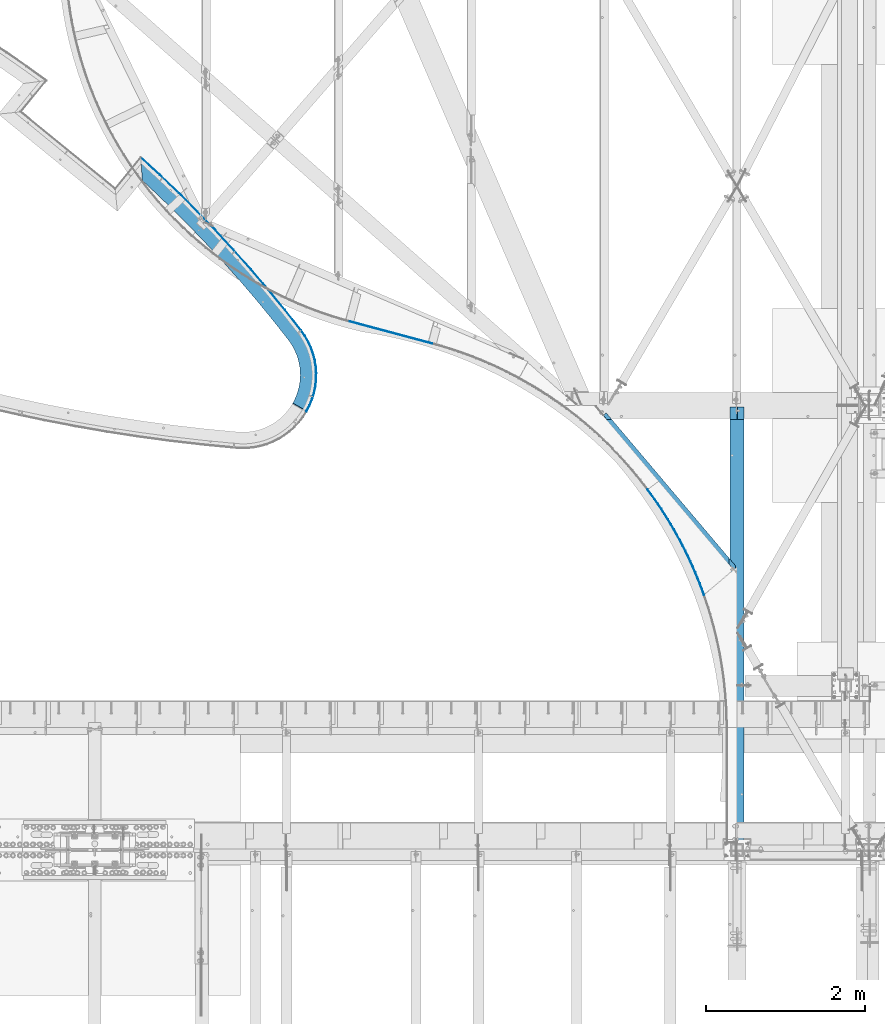
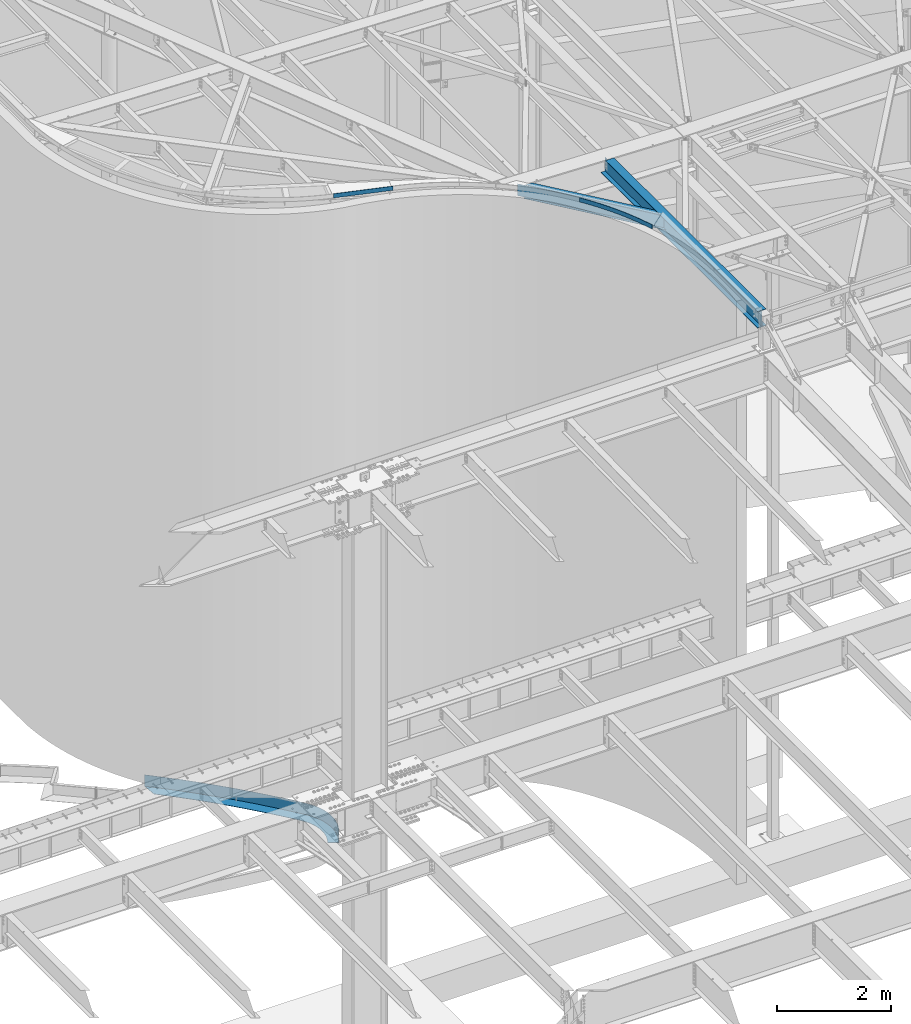
# One storey, part 1147 of 1763: 6 beams, 4 elements without a shape of their own.
"""IFC2X3 building model written with IfcOpenShell, lengths in millimetres."""

from ifc_helpers import new_model, si_unit, frame, origin_with_axes, place, context, subcontext, project, spatial, faceted_brep, material, type_object, element, aggregate, save


model = new_model("IFC2X3")

# Units and contexts
model_context = context("Model", 3, precision=1e-05, world=origin_with_axes())
body_context = subcontext(model_context, "Body", "Model", "MODEL_VIEW")
ifc_project = project(units=[si_unit("LENGTHUNIT", "METRE", prefix="MILLI"), si_unit("AREAUNIT", "SQUARE_METRE"), si_unit("VOLUMEUNIT", "CUBIC_METRE"), si_unit("MASSUNIT", "GRAM", prefix="KILO"), si_unit("TIMEUNIT", "SECOND"), si_unit("PLANEANGLEUNIT", "RADIAN"), si_unit("SOLIDANGLEUNIT", "STERADIAN"), si_unit("THERMODYNAMICTEMPERATUREUNIT", "DEGREE_CELSIUS"), si_unit("LUMINOUSINTENSITYUNIT", "LUMEN")], contexts=[model_context])

# Site, building, storey
site_placement = place(None, origin_with_axes())
site = spatial("IfcSite", under=ifc_project, at=site_placement, CompositionType="ELEMENT")
building_placement = place(site_placement, origin_with_axes())
building = spatial("IfcBuilding", under=site, at=building_placement, Name="Undefined", CompositionType="ELEMENT")
storey_placement = place(building_placement, origin_with_axes())
storey = spatial("IfcBuildingStorey", under=building, at=storey_placement, Name="Undefined", CompositionType="ELEMENT", Elevation=0.0)

# Assembly, beams
assembly_1_placement = place(storey_placement, origin_with_axes())
assembly_1 = element("IfcElementAssembly", 1, at=assembly_1_placement, inside=storey, Name="PLATE", AssemblyPlace="NOTDEFINED", PredefinedType="RIGID_FRAME")
ifc_material_1 = material(Name="STEEL/A36")
beam_type_1 = type_object("IfcBeamType", PredefinedType="NOTDEFINED")
beam_1_placement = place(assembly_1_placement, frame((-48899.7311067183, 60744.4936848839, -250.825), z_axis=(-0.700889581172582, -0.713269791175627, 0.0), x_axis=(0.713269791175628, -0.700889581172581, 0.0)))
beam_1 = element("IfcBeam", 2, at=beam_1_placement, type_object=beam_type_1, material=ifc_material_1, Name="PLATE", context=body_context, shape_type="Brep", body=[
    faceted_brep([(3719.33623650917, 7.91079060036282e-08, 714.45913053512), (3717.48053077907, 3.17499973110492, 708.380531383253), (3526.81825230109, 3.17500026889508, 758.027630323701), (3528.67394264099, 9.33366379740619e-08, 764.106170379902), (3494.29718461835, 3.17500026889508, 664.28157329591), (3494.29718460236, -3.17499973110492, 664.281573302684), (3513.43892058598, -3.17499973110492, 714.20199762013), (3513.43892060238, 3.17500026889508, 714.201997614484), (3471.71765696332, 3.17500026889508, 615.825898084116), (3471.71765694785, -3.17499973110492, 615.825898091989), (3445.79959073293, 3.17500026889508, 569.052919037789), (3445.79959071806, -3.17499973110492, 569.052919046724), (3417.40967095453, 3.17500026889508, 525.336417431874), (3417.40967094037, -3.17499973110492, 525.336417441937), (3385.86149135047, 3.17500026889508, 484.683425487088), (3385.86149124734, -3.17499973110492, 484.683425382475), (3348.17159766036, 3.17500272120952, 443.143611717485), (3348.17159756071, -3.17499727879047, 443.143611616699), (3347.48148950403, 3.17500271957653, 442.442355498355), (3347.48148950389, -3.17499728042347, 442.442355498493), (3311.82468044292, -3.17499728041125, 408.47127432629), (3311.82468044305, 3.17500271958875, 408.471274326144), (3274.05442623266, 3.17500271719913, 376.866681538017), (3274.05442623263, -3.17499728280086, 376.866681538046), (3273.27991684059, 3.17500271496723, 376.259928631091), (3273.27991684056, -3.17499728503279, 376.259928631134), (3227.7524592525, 3.17500000061955, 343.482356215845), (3227.75245925249, -3.17499999938045, 343.482356215882), (3183.80776864987, 3.17500000061955, 316.708360037901), (3183.80776864986, -3.17499999938045, 316.708360037945), (3137.18097810568, 3.17500000061955, 293.42634960567), (3137.18097810568, -3.17499999938045, 293.426349605706), (3087.78670530255, 3.17500000061955, 272.940252532742), (3087.78670530253, -3.17499999938045, 272.940252532779), (3037.09656629767, 3.17500000061955, 255.961054376832), (3037.09656629765, -3.17499999938045, 255.961054376861), (2985.33463682051, 3.17500000061955, 242.561818135055), (2985.33463682017, -3.17499999938045, 242.561818135004), (2930.38702798114, 3.17500000627177, 232.365032070429), (2930.3870279808, -3.17499999372822, 232.365032070385), (2929.39717863227, 3.17500000623701, 232.227819105432), (2929.39717863229, -3.17499999376298, 232.227819105432), (2606.76330909597, -3.17499999506504, 190.856892663844), (2606.76330909594, 3.17500000493496, 190.856892663844), (2283.35200185691, -3.17499999621518, 156.081992570125), (2283.35200185688, 3.17500000378482, 156.081992570118), (1959.29809386149, -3.17499999721298, 127.917617208335), (1959.29809386148, 3.17500000278702, 127.917617208335), (1634.73668996988, -3.17499999805798, 106.375508896348), (1634.73668996988, 3.17500000194201, 106.375508896348), (1309.80310662788, -3.17499999874988, 91.4646489902188), (1309.80310662788, 3.17500000125011, 91.4646489902188), (984.632815450692, -3.17499999928833, 83.1912541396923), (984.632815450677, 3.17500000071166, 83.1912541396923), (659.361386741963, -3.17499999967313, 81.5587736963171), (659.361386741963, 3.17500000032686, 81.5587736963171), (334.124432971716, -3.17499999990412, 86.5678882753818), (334.124432971716, 3.17500000009588, 86.5678882753891), (222.037116683074, 3.1750000000693, 90.5844853690542), (222.037116683074, -3.17499999993072, 90.5844853690542), (6.65585226372059, 3.17499999998279, -98.6635093847108), (6.65585226372059, -3.17500000001721, -98.6635093847108), (329.083712204767, 3.17500000005927, -110.217562492919), (329.083712204767, -3.17499999994075, -110.217562492919), (658.339599024868, 3.1750000002931, -115.288574392998), (658.339599024868, -3.1749999997069, -115.288574392998), (987.630386788151, 3.17500000068267, -113.635921489116), (987.63038678818, -3.17499999931732, -113.635921489116), (1316.81878726966, 3.17500000122777, -105.260292806863), (1316.81878726966, -3.17499999877222, -105.260292806863), (1645.76755493179, 3.1750000019282, -90.165180321248), (1645.76755493179, -3.1749999980718, -90.1651803212408), (1974.33954414494, 3.17500000278363, -68.3568775007552), (1974.33954414494, -3.17499999721636, -68.3568775007407), (2302.39776636627, 3.17500000379377, -39.8444766834909), (2302.39776636628, -3.17499999620622, -39.8444766834982), (2629.80544725322, 3.17500000495815, -4.63986528645546), (2629.80544725325, -3.17499999504187, -4.63986528645546), (2956.42608368752, 3.1750000062373, 37.2422791506651), (2956.4260836875, -3.17499999372373, 37.2422791506651), (2961.87635873359, 3.17500000622621, 37.9977965432881), (2961.87635873327, -3.17499999377378, 37.9977965432445), (3028.01057783778, 3.17499999938045, 50.2705141009828), (3028.01057783746, -3.17500000061955, 50.2705141009392), (3093.09187443195, 3.17499999938045, 67.1176385570216), (3093.09187443195, -3.17500000061955, 67.1176385570579), (3156.83944230023, 3.17499999938045, 88.4705606054085), (3156.83944230022, -3.17500000061955, 88.4705606054486), (3218.95752151059, 3.17499999938045, 114.233810643735), (3218.95752151059, -3.17500000061955, 114.233810643767), (3279.15656184648, 3.17499999938045, 144.292810389386), (3279.15656184645, -3.17500000061955, 144.292810389419), (3336.63126608428, 3.17499999938045, 179.310180872406), (3336.63126608428, -3.17500000061955, 179.310180872442), (3391.53446451016, 3.17500271372811, 218.837834239628), (3391.53446451014, -3.17499728627189, 218.837834239661), (3395.45101705811, 3.17500271356221, 221.906072879159), (3395.45101705803, -3.17499728403999, 221.906072879243), (3442.94745842232, 3.17500271355249, 261.649138410154), (3442.9474584222, -3.17499728644751, 261.649138410303), (3487.78622311432, 3.17500271119454, 304.368084808593), (3487.78622311169, -3.17499728646229, 304.36808480629), (3491.27558591682, 3.17500270746885, 307.913815059579), (3491.27558581716, -3.17499729253117, 307.913814958796), (3536.73477437413, 3.17499973110492, 358.016535915162), (3536.73477427098, -3.17500026889508, 358.016535810548), (3577.99641527353, 3.17499973110492, 411.1862964582), (3577.99641525939, -3.17500026889508, 411.186296468255), (3614.64332047252, 3.17499973110492, 467.617399556944), (3614.64332045765, -3.17500026889508, 467.617399565879), (3647.23780667874, 3.17499973110492, 526.438964669036), (3647.23780666327, -3.17500026889508, 526.438964676905), (3675.63363447004, 3.17499973110492, 587.376422256668), (3675.63363445406, -3.17500026889508, 587.376422263442), (3699.70259318674, 3.17499973110492, 650.146728619879), (3699.70259317032, -3.17500026889508, 650.146728625525), (3719.33622112514, -3.17500026889508, 714.459071489386), (3528.67394263258, -3.17499973110492, 764.106170382085)], [[[0, 1, 2, 3]], [[4, 5, 6, 7]], [[8, 9, 5, 4]], [[10, 11, 9, 8]], [[12, 13, 11, 10]], [[14, 15, 13, 12]], [[16, 17, 15, 14]], [[18, 19, 17, 16]], [[20, 19, 18, 21]], [[22, 23, 20, 21]], [[24, 25, 23, 22]], [[26, 27, 25, 24]], [[28, 29, 27, 26]], [[30, 31, 29, 28]], [[32, 33, 31, 30]], [[34, 35, 33, 32]], [[36, 37, 35, 34]], [[38, 39, 37, 36]], [[40, 41, 39, 38]], [[42, 41, 40, 43]], [[44, 42, 43, 45]], [[46, 44, 45, 47]], [[48, 46, 47, 49]], [[50, 48, 49, 51]], [[52, 50, 51, 53]], [[54, 52, 53, 55]], [[56, 54, 55, 57]], [[56, 57, 58, 59]], [[60, 61, 59, 58]], [[62, 63, 61, 60]], [[62, 64, 65, 63]], [[64, 66, 67, 65]], [[66, 68, 69, 67]], [[68, 70, 71, 69]], [[70, 72, 73, 71]], [[72, 74, 75, 73]], [[74, 76, 77, 75]], [[76, 78, 79, 77]], [[79, 78, 80, 81]], [[81, 80, 82, 83]], [[83, 82, 84, 85]], [[85, 84, 86, 87]], [[87, 86, 88, 89]], [[89, 88, 90, 91]], [[91, 90, 92, 93]], [[93, 92, 94, 95]], [[95, 94, 96, 97]], [[97, 96, 98, 99]], [[98, 100, 101, 99]], [[101, 100, 102, 103]], [[103, 102, 104, 105]], [[105, 104, 106, 107]], [[107, 106, 108, 109]], [[109, 108, 110, 111]], [[111, 110, 112, 113]], [[113, 112, 114, 115]], [[6, 5, 9, 11, 13, 15, 17, 19, 20, 23, 25, 27, 29, 31, 33, 35, 37, 39, 41, 42, 44, 46, 48, 50, 52, 54, 56, 59, 61, 63, 65, 67, 69, 71, 73, 75, 77, 79, 81, 83, 85, 87, 89, 91, 93, 95, 97, 99, 101, 103, 105, 107, 109, 111, 113, 115, 116, 117]], [[117, 116, 0, 3]], [[7, 6, 117, 3, 2]], [[114, 112, 110, 108, 106, 104, 102, 100, 98, 96, 94, 92, 90, 88, 86, 84, 82, 80, 78, 76, 74, 72, 70, 68, 66, 64, 62, 60, 58, 57, 55, 53, 51, 49, 47, 45, 43, 40, 38, 36, 34, 32, 30, 28, 26, 24, 22, 21, 18, 16, 14, 12, 10, 8, 4, 7, 2, 1]], [[116, 115, 114, 1, 0]]]),
])
beam_type_2 = type_object("IfcBeamType", PredefinedType="NOTDEFINED")
beam_2_placement = place(assembly_1_placement, frame((-46745.1844224407, 57625.6066040922, -130.175), z_axis=(0.0, 0.0, 1.0), x_axis=(0.228262231888325, 0.973599688523656, 0.0)))
beam_2 = element("IfcBeam", 3, at=beam_2_placement, type_object=beam_type_2, material=ifc_material_1, Name="PLATE", context=body_context, shape_type="Brep", body=[
    faceted_brep([(7.97817378518084, 1.33556777716876, 123.825), (7.97797555410943, 1.3347914737169, -123.825), (0.924497725944093, -0.137603153845703, -123.825), (0.924497725944093, -0.137603153845703, 123.825), (-5.0931703299284e-10, -3.17499999955908, 123.825), (-5.0931703299284e-10, -3.17499999955908, -123.825), (80.8035300380943, -23.808387718469, -123.825), (80.8035300380943, -23.808387718469, 123.825), (163.146523037532, -37.021209497143, -123.825), (163.146523037532, -37.021209497143, 123.825), (246.348981190975, -42.704352349705, -123.825), (246.348981190975, -42.704352349705, 123.825), (329.723809130584, -40.8108842357615, -123.825), (329.723809130584, -40.8108842357615, 123.825), (412.58248803921, -31.3564416304434, -123.825), (412.58248803921, -31.3564416304434, 123.825), (494.240761517111, -14.4191003967135, -123.825), (494.240761517111, -14.4191003967135, 123.825), (574.024286249216, 9.86126897404756, -123.825), (574.024286249216, 9.86126897404756, 123.825), (651.274200808934, 41.2841564284827, -123.825), (651.274200808934, 41.2841564284827, 123.825), (725.352566610825, 79.5900681860876, -123.825), (725.352566610825, 79.5900681860876, 123.825), (795.647636079979, 124.462669668341, -123.825), (795.647636079979, 124.462669668341, 123.825), (861.578904533162, 175.531397825725, -123.825), (861.578904533162, 175.531397825725, 123.825), (922.601904052535, 232.374521289508, -123.825), (922.601904052535, 232.374521289508, 123.825), (978.212699763644, 294.52262307737, -123.825), (978.212699763644, 294.52262307737, 123.825), (1184.26767369515, 552.348585428539, -123.825), (1184.26767369515, 552.348585428539, 123.825), (1385.0026837896, 814.337773882173, -123.825), (1385.0026837896, 814.337773882173, 123.825), (1580.3336375744, 1080.38043519374, -123.825), (1580.3336375744, 1080.38043519374, 123.825), (1770.17870645933, 1350.36511802645, -123.825), (1770.17870645933, 1350.36511802645, 123.825), (1954.45836001647, 1624.17871964089, -123.825), (1954.45836001647, 1624.17871964089, 123.825), (2133.09539929726, 1901.70653327622, -123.825), (2133.09539929726, 1901.70653327622, 123.825), (2306.0149891729, 2182.83229620351, -123.825), (2306.0149891729, 2182.83229620351, 123.825), (2473.14468968454, 2467.43823843083, -123.825), (2473.14468968454, 2467.43823843083, 123.825), (2634.41448638998, 2755.40513203979, -123.825), (2634.41448638998, 2755.40513203979, 123.825), (2625.58851084853, 2752.64031056342, -123.825), (2625.58851084853, 2752.64031056342, 123.825), (2467.63638795279, 2470.59752822945, -123.825), (2467.63638795279, 2470.59752822945, 123.825), (2300.57250092307, 2186.10366008578, 123.825), (2300.57250092307, 2186.10366008578, -123.825), (2127.72100451177, 1905.08860079321, 123.825), (2127.72100451177, 1905.08860079321, -123.825), (1949.15431015183, 1627.67007396741, 123.825), (1949.15431015183, 1627.67007396741, -123.825), (1764.94722350298, 1353.96429655456, 123.825), (1764.94722350298, 1353.96429655456, -123.825), (1575.17691311381, 1084.08593014548, 123.825), (1575.17691311381, 1084.08593014548, -123.825), (1379.92287809426, 818.148032941252, 123.825), (1379.92287809426, 818.148032941252, -123.825), (1179.26691481146, 556.262012390544, 123.825), (1179.26691481146, 556.262012390544, -123.825), (973.293082623532, 298.537578518524, -123.825), (973.293082623532, 298.537578518539, 123.825), (918.06707919122, 236.819503120401, 123.825), (918.06707919122, 236.819503120401, -123.825), (857.466321050422, 180.36969888056, 123.825), (857.466321050422, 180.36969888056, -123.825), (791.991256158202, 129.654334706407, 123.825), (791.991256158202, 129.654334706407, -123.825), (722.182585051516, 85.092223846681, 123.825), (722.182585051516, 85.092223846681, -123.825), (648.616795680551, 47.0513652840382, 123.825), (648.616795680551, 47.0513652840382, -123.825), (571.90140270572, 15.8459047575016, 123.825), (571.90140270572, 15.8459047575016, -123.825), (492.669930572389, -8.2664594887101, 123.825), (492.669930572389, -8.2664594887101, -123.825), (411.576681793966, -25.08660480666, 123.825), (411.576681793966, -25.08660480666, -123.825), (329.291333647248, -34.4756285222029, 123.825), (329.291333647248, -34.4756285222029, -123.825), (246.493407901304, -36.3559950090203, 123.825), (246.493407901304, -36.3559950090203, -123.825), (163.86665924931, -30.7121759866641, 123.825), (163.86665924931, -30.7121759866641, -123.825), (82.0934287845521, -17.5907787549077, 123.825), (82.0934287845521, -17.5907787549077, -123.825)], [[[0, 1, 2, 3]], [[4, 5, 6, 7]], [[6, 8, 9, 7]], [[8, 10, 11, 9]], [[10, 12, 13, 11]], [[12, 14, 15, 13]], [[14, 16, 17, 15]], [[16, 18, 19, 17]], [[18, 20, 21, 19]], [[20, 22, 23, 21]], [[22, 24, 25, 23]], [[24, 26, 27, 25]], [[26, 28, 29, 27]], [[28, 30, 31, 29]], [[31, 30, 32, 33]], [[32, 34, 35, 33]], [[34, 36, 37, 35]], [[36, 38, 39, 37]], [[38, 40, 41, 39]], [[40, 42, 43, 41]], [[42, 44, 45, 43]], [[44, 46, 47, 45]], [[47, 46, 48, 49]], [[50, 51, 49, 48]], [[52, 53, 51, 50]], [[54, 53, 52, 55]], [[56, 54, 55, 57]], [[58, 56, 57, 59]], [[60, 58, 59, 61]], [[62, 60, 61, 63]], [[64, 62, 63, 65]], [[66, 64, 65, 67]], [[68, 69, 66, 67]], [[70, 69, 68, 71]], [[72, 70, 71, 73]], [[74, 72, 73, 75]], [[76, 74, 75, 77]], [[78, 76, 77, 79]], [[80, 78, 79, 81]], [[82, 80, 81, 83]], [[84, 82, 83, 85]], [[86, 84, 85, 87]], [[88, 86, 87, 89]], [[90, 88, 89, 91]], [[92, 90, 91, 93]], [[4, 7, 9, 11, 13, 15, 17, 19, 21, 23, 25, 27, 29, 31, 33, 35, 37, 39, 41, 43, 45, 47, 49, 51, 53, 54, 56, 58, 60, 62, 64, 66, 69, 70, 72, 74, 76, 78, 80, 82, 84, 86, 88, 90, 92, 0, 3]], [[5, 4, 3, 2]], [[93, 91, 89, 87, 85, 83, 81, 79, 77, 75, 73, 71, 68, 67, 65, 63, 61, 59, 57, 55, 52, 50, 48, 46, 44, 42, 40, 38, 36, 34, 32, 30, 28, 26, 24, 22, 20, 18, 16, 14, 12, 10, 8, 6, 5, 2, 1]], [[92, 93, 1, 0]]]),
])
aggregate(assembly_1, [beam_2, beam_1])

# Assembly, beam
assembly_2_placement = place(storey_placement, origin_with_axes())
assembly_2 = element("IfcElementAssembly", 4, at=assembly_2_placement, inside=storey, Name="BEAM", AssemblyPlace="NOTDEFINED", PredefinedType="RIGID_FRAME")
beam_type_3 = type_object("IfcBeamType", PredefinedType="NOTDEFINED")
beam_3_placement = place(assembly_2_placement, frame((-45164.0422273018, 58477.7345624664, 12639.0206884602), z_axis=(0.0279603370251352, -0.00749183800673927, 0.999580958160329), x_axis=(-0.965522028116381, 0.258706987031184, 0.0289466420034886)))
beam_3 = element("IfcBeam", 5, at=beam_3_placement, type_object=beam_type_3, material=ifc_material_1, Name="PLATE", context=body_context, shape_type="Brep", body=[
    faceted_brep([(0.0, 3.17500000000291, -44.4500000000007), (0.0, 3.17500000000291, 44.4500000000007), (1074.64462097271, 3.17500000246218, 44.4500000001917), (1074.64462097239, 3.17500000252039, -44.449999999737), (0.0, -3.17500000000291, 44.4500000000007), (1074.6446209727, -3.17499999752908, 44.4500000001917), (0.0, -3.17500000000291, -44.4500000000007), (1074.64462097237, -3.17499999747088, -44.4499999997388)], [[[0, 1, 2, 3]], [[1, 4, 5, 2]], [[4, 6, 7, 5]], [[6, 0, 3, 7]], [[5, 7, 3, 2]], [[6, 4, 1, 0]]]),
])
aggregate(assembly_2, [beam_3])

assembly_3_placement = place(storey_placement, origin_with_axes())
assembly_3 = element("IfcElementAssembly", 6, at=assembly_3_placement, inside=storey, Name="BEAM", AssemblyPlace="NOTDEFINED", PredefinedType="RIGID_FRAME")
beam_4_placement = place(assembly_3_placement, frame((-41753.0296274589, 55323.23427328, 12530.1292307321), z_axis=(0.0084324701376463, -0.0157635252573236, 0.999840189589736), x_axis=(-0.47161242214502, 0.881624709271097, 0.0178772280054969)))
beam_4 = element("IfcBeam", 7, at=beam_4_placement, type_object=beam_type_3, material=ifc_material_1, Name="PLATE", context=body_context, shape_type="Brep", body=[
    faceted_brep([(0.477247044094838, 3.13892660942474, -44.4500000000135), (0.477247044298565, 3.13892660924466, 44.4500000000098), (74.9654360330896, -7.61206415345987, 44.4499999999825), (74.9654360328714, -7.61206415328888, -44.4500000000389), (-0.477247044094838, -3.13892660944293, 44.4500000000098), (-0.477247044298565, -3.13892660926649, -44.4500000000135), (74.1057709565648, -13.9036041839026, -44.4500000000407), (74.105770956754, -13.9036041840754, 44.4499999999844), (149.607357125642, -17.23795199911, 44.4499999999553), (149.607357125453, -17.237951998939, -44.450000000068), (148.842716773637, -23.5417465016635, -44.4500000000662), (148.842716773826, -23.5417465018381, 44.4499999999571), (224.386017249708, -25.7365454861356, 44.4499999999298), (224.386017249533, -25.7365454859573, -44.4500000000935), (223.716575701153, -32.0511593311239, -44.4500000000935), (223.716575701357, -32.0511593313022, 44.4499999999298), (299.284392202768, -33.1059098142014, 44.4499999999025), (299.284392202564, -33.1059098140213, -44.4500000001226), (298.710301863583, -39.4299054088096, -44.4500000001208), (298.710301863772, -39.4299054089843, 44.4499999999025), (374.285430527903, -39.3443672646754, 44.4499999998752), (374.2854305277, -39.3443672644971, -44.4500000001499), (373.806822096187, -45.6763048802277, -44.4500000001462), (373.806822096376, -45.6763048804078, 44.4499999998734), (449.372057395696, -44.4504975826185, 44.4499999998461), (449.372057395507, -44.4504975824402, -44.4500000001754), (448.989039832057, -50.7889356823471, -44.4500000001754), (448.989039832246, -50.7889356825253, 44.4499999998479), (524.527178491611, -48.4231383000606, 44.449999999817), (524.527178491408, -48.4231382998787, -44.4500000002045), (524.239838994283, -54.7666338672825, -44.4500000002045), (524.239838994472, -54.7666338674571, 44.4499999998206), (599.733683907529, -51.2613850006801, 44.4499999997934), (599.73368390734, -51.2613850005109, -44.4500000002317), (599.542087892609, -57.6084938673412, -44.4500000002317), (599.542087892798, -57.6084938675085, 44.4499999997915), (674.974452037204, -52.9645915257406, 44.4499999997624), (674.974452037015, -52.9645915255569, -44.450000000259), (674.878643123637, -59.3138687011378, -44.450000000259), (674.87864312384, -59.3138687013161, 44.4499999997643), (750.232353474043, -53.5323701210982, 44.4499999997352), (750.232353473839, -53.5323701209236, -44.4500000002881), (750.232353473839, -59.8823701209367, -44.4500000002863), (750.232353474028, -59.8823701211149, 44.4499999997352), (825.490254910881, -52.9645915256006, 44.4499999997061), (825.490254910692, -52.9645915254187, -44.4500000003154), (825.586063824041, -59.313868700996, -44.4500000003154), (825.58606382423, -59.313868701176, 44.4499999997097), (900.731023040571, -51.2613850004163, 44.4499999996806), (900.731023040367, -51.2613850002381, -44.4500000003445), (900.922619055069, -57.608493867061, -44.4500000003427), (900.922619055273, -57.6084938672375, 44.4499999996788), (975.937528456503, -48.4231382996513, 44.4499999996497), (975.937528456314, -48.4231382994731, -44.4500000003736), (976.22486795341, -54.7666338668678, -44.4500000003736), (976.224867953613, -54.7666338670515, 44.4499999996515), (1051.09264955242, -44.4504975820746, 44.4499999996206), (1051.09264955223, -44.4504975819054, -44.4500000004009), (1051.47566711565, -50.7889356817977, -44.4500000004009), (1051.47566711584, -50.7889356819778, 44.4499999996224), (1126.17927642024, -39.3443672639969, 44.4499999995915), (1126.17927642004, -39.3443672638223, -44.45000000043), (1126.65788485153, -45.6763048795474, -44.4500000004282), (1126.65788485174, -45.6763048797293, 44.4499999995933), (1201.18031474539, -33.1059098133846, 44.4499999995642), (1201.1803147452, -33.1059098132027, -44.4500000004591), (1201.75440508415, -39.4299054079947, -44.4500000004591), (1201.75440508436, -39.4299054081675, 44.4499999995642), (1276.07868969846, -25.7365454851843, 44.4499999995351), (1276.07868969828, -25.7365454850169, -44.4500000004882), (1276.74813124661, -32.0511593301726, -44.4500000004882), (1276.7481312468, -32.0511593303509, 44.4499999995351), (1350.85734982257, -17.2379519980313, 44.4499999995078), (1350.85734982237, -17.2379519978513, -44.4500000005173), (1351.62199017417, -23.5417465005758, -44.4500000005155), (1351.62199017436, -23.5417465007522, 44.4499999995078), (1425.49927091518, -7.6120641522466, 44.4499999994769), (1425.49927091498, -7.61206415206652, -44.4500000005464), (1426.3589359913, -13.9036041826766, -44.4500000005446), (1426.35893599148, -13.9036041828549, 44.4499999994769), (1499.987459904, 3.13892661060345, 44.4499999994478), (1499.9874599038, 3.13892661078171, -44.4500000005755), (1500.94195399238, -3.13892660808051, 44.4499999994496), (1500.94195399217, -3.13892660791316, -44.4500000005737)], [[[0, 1, 2, 3]], [[4, 5, 6, 7]], [[5, 4, 1, 0]], [[3, 2, 8, 9]], [[7, 6, 10, 11]], [[9, 8, 12, 13]], [[11, 10, 14, 15]], [[13, 12, 16, 17]], [[15, 14, 18, 19]], [[17, 16, 20, 21]], [[19, 18, 22, 23]], [[21, 20, 24, 25]], [[23, 22, 26, 27]], [[25, 24, 28, 29]], [[27, 26, 30, 31]], [[29, 28, 32, 33]], [[31, 30, 34, 35]], [[33, 32, 36, 37]], [[35, 34, 38, 39]], [[37, 36, 40, 41]], [[39, 38, 42, 43]], [[41, 40, 44, 45]], [[43, 42, 46, 47]], [[45, 44, 48, 49]], [[47, 46, 50, 51]], [[49, 48, 52, 53]], [[51, 50, 54, 55]], [[53, 52, 56, 57]], [[55, 54, 58, 59]], [[57, 56, 60, 61]], [[59, 58, 62, 63]], [[61, 60, 64, 65]], [[63, 62, 66, 67]], [[65, 64, 68, 69]], [[67, 66, 70, 71]], [[69, 68, 72, 73]], [[71, 70, 74, 75]], [[73, 72, 76, 77]], [[75, 74, 78, 79]], [[77, 76, 80, 81]], [[76, 72, 68, 64, 60, 56, 52, 48, 44, 40, 36, 32, 28, 24, 20, 16, 12, 8, 2, 1, 4, 7, 11, 15, 19, 23, 27, 31, 35, 39, 43, 47, 51, 55, 59, 63, 67, 71, 75, 79, 82, 80]], [[79, 78, 83, 82]], [[78, 74, 70, 66, 62, 58, 54, 50, 46, 42, 38, 34, 30, 26, 22, 18, 14, 10, 6, 5, 0, 3, 9, 13, 17, 21, 25, 29, 33, 37, 41, 45, 49, 53, 57, 61, 65, 69, 73, 77, 81, 83]], [[82, 83, 81, 80]]]),
])

assembly_4_placement = place(storey_placement, origin_with_axes())
assembly_4 = element("IfcElementAssembly", 8, at=assembly_4_placement, inside=storey, Name="BEAM", AssemblyPlace="NOTDEFINED", PredefinedType="RIGID_FRAME")
ifc_material_2 = material(Name="STEEL/A992")
beam_type_4 = type_object("IfcBeamType", Name="W14X30", PredefinedType="NOTDEFINED")
beam_5_placement = place(assembly_4_placement, frame((-41338.538221772, 52044.6000000041, 12318.801563), z_axis=(0.0, 0.0, 1.0), x_axis=(0.0, 1.0, 0.0)))
beam_5 = element("IfcBeam", 9, at=beam_5_placement, type_object=beam_type_4, material=ifc_material_2, Name="BEAM", ObjectType="W14X30", context=body_context, shape_type="Brep", body=[
    faceted_brep([(165.099999996914, -3.17500000000291, -166.6875), (165.099999996914, -85.7249999999985, -166.6875), (5637.21249999524, -85.7249999999985, -166.6875), (5637.21249999524, -3.17500000000291, -166.6875), (165.099999996914, -85.7249999999985, -176.2125), (5637.21249999524, -85.7249999999985, -176.2125), (165.099999996914, 85.7249999999985, -176.2125), (5637.21249999524, 85.7249999999985, -176.2125), (165.099999996914, 85.7249999999985, -166.6875), (165.099999996914, 3.17500000000291, -166.6875), (5637.21249999524, 3.17500000000291, -166.6875), (5637.21249999524, 85.7249999999985, -166.6875), (5637.21249999524, 3.17500000000291, 123.985770727428), (5637.21249999524, -3.17500000000291, 123.985770727428), (165.099999996914, -3.17500000000291, 166.6875), (165.099999996914, -85.7249999999985, 166.6875), (165.099999996914, -85.7249999999985, 176.2125), (165.099999996914, 85.7249999999985, 176.2125), (165.099999996914, 85.7249999999985, 166.6875), (165.099999996914, 3.17500000000291, 166.6875), (5481.637503047, 85.7249999999985, 166.6875), (5481.637503047, 3.17500000000291, 166.6875), (5481.637503047, 3.17500000000291, 136.685770536693), (5482.60423296958, 3.17500000000291, 131.825691018646), (5485.35724687007, 3.17500000000291, 127.705514550493), (5489.47742333822, 3.17500000000291, 124.952500650015), (5494.33750285627, 3.17500000000291, 123.985770727428), (5482.60423296958, -3.17500000000291, 131.825691018646), (5481.637503047, -3.17500000000291, 136.685770536693), (5485.35724687007, -3.17500000000291, 127.705514550493), (5489.47742333822, -3.17500000000291, 124.952500650015), (5494.33750285627, -3.17500000000291, 123.985770727428), (5481.637503047, -3.17500000000291, 166.6875), (5481.637503047, -85.7249999999985, 166.6875), (5481.637503047, -85.7249999999985, 176.2125), (5481.637503047, 85.7249999999985, 176.2125)], [[[0, 1, 2, 3]], [[1, 4, 5, 2]], [[4, 6, 7, 5]], [[8, 9, 10, 11]], [[3, 2, 5, 7, 11, 10, 12, 13]], [[6, 8, 11, 7]], [[4, 1, 0, 14, 15, 16, 17, 18, 19, 9, 8, 6]], [[19, 18, 20, 21]], [[10, 9, 19, 21, 22, 23, 24, 25, 26, 12]], [[27, 23, 22, 28]], [[29, 24, 23, 27]], [[30, 25, 24, 29]], [[31, 26, 25, 30]], [[13, 12, 26, 31]], [[30, 29, 27, 28, 32, 14, 0, 3, 13, 31]], [[15, 14, 32, 33]], [[16, 15, 33, 34]], [[17, 16, 34, 35]], [[18, 17, 35, 20]], [[34, 33, 32, 28, 22, 21, 20, 35]]]),
])
aggregate(assembly_4, [beam_5])

# Beam
beam_type_5 = type_object("IfcBeamType", Name="W12X14", PredefinedType="NOTDEFINED")
beam_6_placement = place(assembly_3_placement, frame((-41340.3160872801, 55590.5826024903, 12346.409500199), z_axis=(0.0117885780861106, -0.0139355481017992, 0.999833401085306), x_axis=(-0.645737618004851, 0.763341181005736, 0.0182529470001375)))
beam_6 = element("IfcBeam", 10, at=beam_6_placement, type_object=beam_type_5, material=ifc_material_2, Name="BEAM", ObjectType="W12X14", context=body_context, shape_type="Brep", body=[
    faceted_brep([(2599.87428057446, 2.68141140903208, -144.462499999689), (2599.87428057467, 2.68108555543949, -150.812499999689), (2599.87424496311, 50.7999999930144, -150.812499999698), (2599.87424496311, 50.7999999930198, -144.4624999997), (2739.20578210596, 2.68151452398979, -144.462499999676), (2739.08958080677, 2.6811885844254, -150.812499999671), (154.651346991843, -2.38125000049695, 118.678409686985), (149.020548921544, 2.38124999954653, 118.678409687715), (147.457674703823, 2.38124999955198, 113.86449537589), (153.08847277415, -2.38125000048331, 113.864495375161), (143.179649179438, 2.3812499995729, 109.795092085826), (148.810447249751, -2.38125000047057, 109.795092085094), (136.828147303255, 2.38124999958382, 107.080582845312), (142.458945373568, -2.38125000045147, 107.080582844583), (129.355851488363, 2.38124999960655, 106.128125719324), (134.986649558661, -2.38125000042965, 106.128125718595), (20.9531313439657, 2.38124999991123, 106.128125740426), (26.5839294109464, -2.38125000012042, 106.128125739664), (16.3783519335411, 2.38125000001946, -144.462499999981), (-40.8680950809503, 50.8000000004095, -144.462499999994), (-40.9840206036024, 50.8000000004149, -150.812499999995), (79.1396714924049, -50.8000000004176, -150.812499999962), (79.2555970150279, -50.8000000004131, -144.462499999961), (22.0091500005365, -2.38125000001946, -144.462499999978), (2599.87431710864, -50.800000007479, -150.81249999968), (2599.87431710865, -50.8000000074808, -144.462499999679), (2599.87428149742, -2.68141140292209, -150.812499999687), (2599.87428149719, -2.68108554932951, -144.462499999689), (2734.66869534068, -2.68098579146317, -144.462499999672), (2734.55249404148, -2.68131173102756, -150.812499999674), (2734.92229481442, -2.38125000762557, -144.462499999674), (2739.39560700457, -2.38125000772015, 100.570087522667), (2552.45688482811, -2.38125000719629, 100.570087472732), (2546.03714339698, -2.38125000717901, 101.553821194639), (2540.61193995495, -2.38125000716627, 104.352623615494), (2537.02173996084, -2.38125000715991, 108.532907905603), (2535.82273252678, -2.38125000716263, 113.447069861453), (2536.38895345894, -2.38125000717264, 144.462500000265), (155.122063863659, -2.3812500005024, 144.4625), (2743.42504746116, 2.38124999228239, 100.570087522121), (2556.48632528263, 2.38124999281354, 100.570087472206), (2550.06658385151, 2.38124999283809, 101.553821194111), (2544.64138040948, 2.38124999284355, 104.352623614965), (2541.05118041536, 2.38124999285083, 108.532907905073), (2539.85217298131, 2.38124999285446, 113.447069860924), (2581.50029813127, 50.7999999929616, 150.81250000026), (2495.53890176765, -50.8000000072971, 150.812500000269), (2495.42297550439, -50.8000000072916, 144.462500000271), (2540.41839391348, 2.38124999283718, 144.462500000267), (2581.38437186801, 50.7999999929561, 144.462500000262), (149.491265793273, 2.38124999953743, 144.462499999996), (92.2448187442642, 50.7999999999338, 144.462499999983), (92.3607449638803, 50.7999999999311, 150.81249999998), (212.484437132269, -50.8000000008979, 150.812500000015), (212.368510912653, -50.8000000009024, 144.462500000014), (2738.95173527104, 2.38124999239153, -144.462499999672)], [[[0, 1, 2, 3]], [[4, 5, 1, 0]], [[6, 7, 8, 9]], [[9, 8, 10, 11]], [[11, 10, 12, 13]], [[13, 12, 14, 15]], [[15, 14, 16, 17]], [[18, 19, 20, 21, 22, 23, 17, 16]], [[22, 21, 24, 25]], [[25, 24, 26, 27]], [[28, 27, 26, 29]], [[30, 23, 22, 25, 27, 28]], [[9, 11, 13, 15, 17, 23, 30, 31, 32, 33, 34, 35, 36, 37, 38, 6]], [[39, 40, 32, 31]], [[41, 33, 32, 40]], [[42, 34, 33, 41]], [[43, 35, 34, 42]], [[44, 36, 35, 43]], [[45, 46, 47, 37, 36, 44, 48, 49]], [[49, 48, 50, 51]], [[45, 49, 51, 52]], [[46, 45, 52, 53]], [[47, 46, 53, 54]], [[37, 47, 54, 38]], [[53, 52, 51, 50, 7, 6, 38, 54]], [[48, 44, 43, 42, 41, 40, 39, 55, 18, 16, 14, 12, 10, 8, 7, 50]], [[3, 19, 18, 55, 4, 0]], [[20, 19, 3, 2]], [[29, 26, 24, 21, 20, 2, 1, 5]], [[55, 39, 31, 30, 28, 29, 5, 4]]]),
])

aggregate(assembly_3, [beam_4, beam_6])

save(model, "model.ifc")
